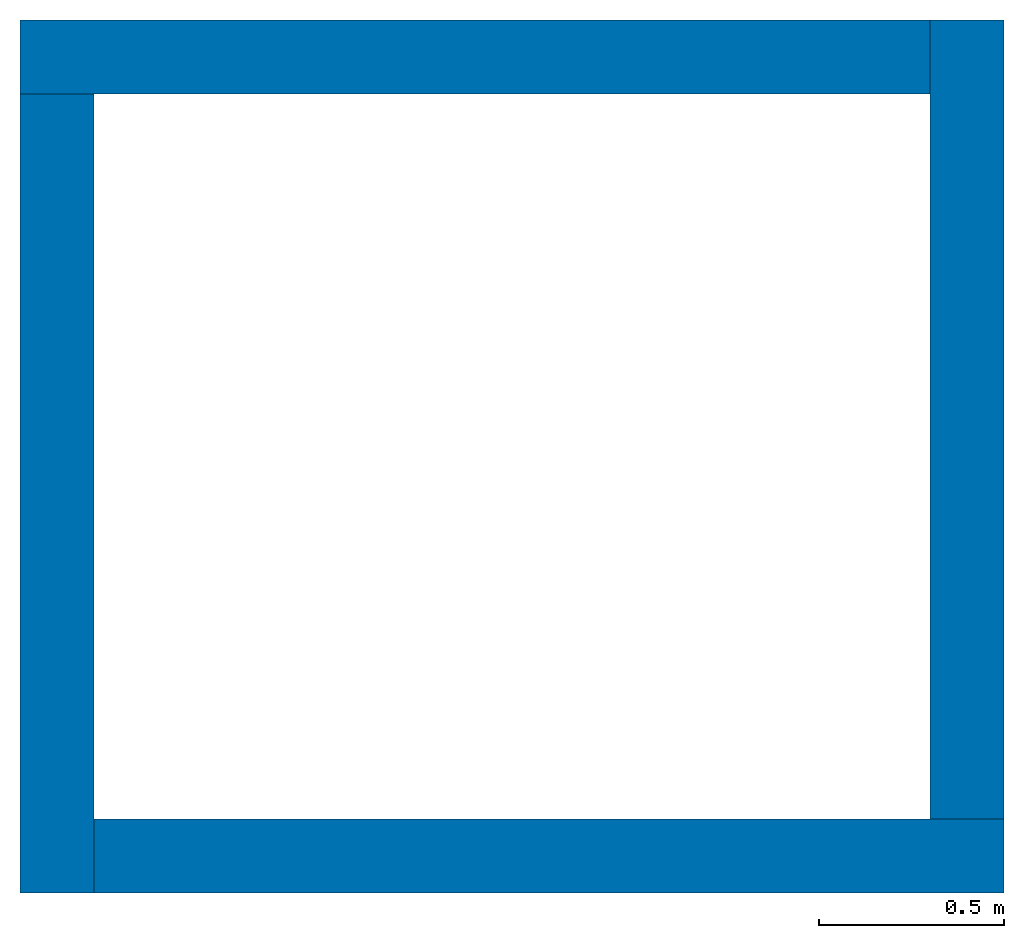
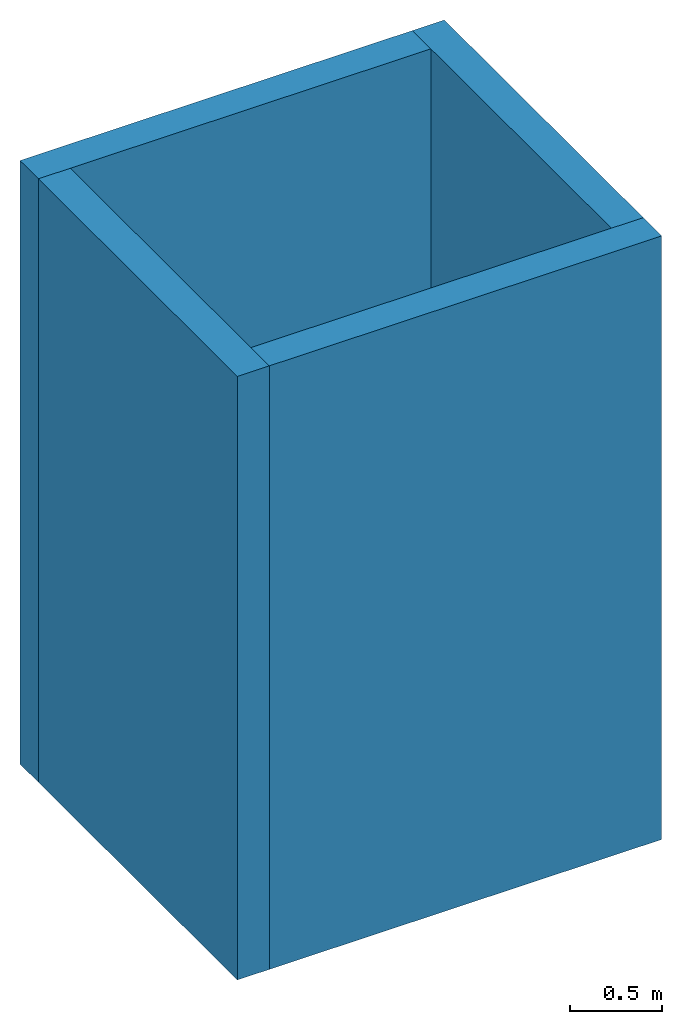
# One storey: 4 walls.
"""IFC2X3 building model written with IfcOpenShell, lengths in millimetres."""

from ifc_helpers import new_model, entity, si_unit, converted_unit, derived_unit, direction, frame, frame_2d, origin, place, context, subcontext, project, spatial, rectangle, extrude, material, layer, layer_set, layer_usage, type_object, element, save


model = new_model("IFC2X3")

# Units and contexts
model_context = context("Model", 3, precision=0.01, world=origin(), true_north=direction((6.12303176911189e-17, 1.0)))
context_of_model = context(None, 3, precision=0.01, world=origin(), true_north=direction((6.12303176911189e-17, 1.0)))
body_context = subcontext(model_context, "Body", "Model", "MODEL_VIEW")
ifc_project = project(units=[si_unit("LENGTHUNIT", "METRE", prefix="MILLI"), si_unit("AREAUNIT", "SQUARE_METRE"), si_unit("VOLUMEUNIT", "CUBIC_METRE"), converted_unit("PLANEANGLEUNIT", "DEGREE", entity("IfcRatioMeasure", 0.0174532925199433), si_unit("PLANEANGLEUNIT", "RADIAN"), dimensions=[0, 0, 0, 0, 0, 0, 0]), si_unit("MASSUNIT", "GRAM", prefix="KILO"), derived_unit("MASSDENSITYUNIT", [(si_unit("MASSUNIT", "GRAM", prefix="KILO"), 1), (si_unit("LENGTHUNIT", "METRE"), -3)]), si_unit("TIMEUNIT", "SECOND"), si_unit("FREQUENCYUNIT", "HERTZ"), si_unit("THERMODYNAMICTEMPERATUREUNIT", "DEGREE_CELSIUS"), derived_unit("THERMALTRANSMITTANCEUNIT", [(si_unit("MASSUNIT", "GRAM", prefix="KILO"), 1), (si_unit("THERMODYNAMICTEMPERATUREUNIT", "KELVIN"), -1), (si_unit("TIMEUNIT", "SECOND"), -3)]), derived_unit("VOLUMETRICFLOWRATEUNIT", [(si_unit("LENGTHUNIT", "METRE"), 3), (si_unit("TIMEUNIT", "SECOND"), -1)]), si_unit("ELECTRICCURRENTUNIT", "AMPERE"), si_unit("ELECTRICVOLTAGEUNIT", "VOLT"), si_unit("POWERUNIT", "WATT"), si_unit("FORCEUNIT", "NEWTON", prefix="KILO"), si_unit("ILLUMINANCEUNIT", "LUX"), si_unit("LUMINOUSFLUXUNIT", "LUMEN"), si_unit("LUMINOUSINTENSITYUNIT", "CANDELA"), derived_unit("USERDEFINED", [(si_unit("MASSUNIT", "GRAM", prefix="KILO"), -1), (si_unit("LENGTHUNIT", "METRE"), -2), (si_unit("TIMEUNIT", "SECOND"), 3), (si_unit("LUMINOUSFLUXUNIT", "LUMEN"), 1)]), derived_unit("LINEARVELOCITYUNIT", [(si_unit("LENGTHUNIT", "METRE"), 1), (si_unit("TIMEUNIT", "SECOND"), -1)]), si_unit("PRESSUREUNIT", "PASCAL"), derived_unit("USERDEFINED", [(si_unit("LENGTHUNIT", "METRE"), -2), (si_unit("MASSUNIT", "GRAM", prefix="KILO"), 1), (si_unit("TIMEUNIT", "SECOND"), -2)])], contexts=[model_context, context_of_model])

# Site, building, storey
site_placement = place(None, origin())
site = spatial("IfcSite", under=ifc_project, at=site_placement, CompositionType="ELEMENT")
building_placement = place(site_placement, origin())
building = spatial("IfcBuilding", under=site, at=building_placement, CompositionType="ELEMENT")
storey_placement = place(building_placement, origin())
storey = spatial("IfcBuildingStorey", under=building, at=storey_placement, Name="Level 1", CompositionType="ELEMENT", Elevation=0.0)

# Walls
ifc_material = material(Name="Default Wall")
ifc_layer = layer(ifc_material, 200.0)
ifc_layer_set = layer_set([ifc_layer], Name="Basic Wall:Wall 1")
ifc_layer_usage_1 = layer_usage(ifc_layer_set, "AXIS2", "NEGATIVE", 100.0)
wall_type = type_object("IfcWallType", Name="Basic Wall:Wall 1", PredefinedType="STANDARD", material=ifc_layer_set)
wall_1_placement = place(storey_placement, frame((524.569707401033, 3115.31841652324, 0.0)))
element("IfcWallStandardCase", 1, at=wall_1_placement, inside=storey, type_object=wall_type, material=ifc_layer_usage_1, Name="Basic Wall:Wall 1:2474", ObjectType="Basic Wall:Wall 1", context=body_context, shape_type="SweptSolid", body=[
    extrude(rectangle(XDim=2460.0, YDim=200.0, at=frame_2d((1230.0, 0.0), x_axis=(-1.0, 0.0))), origin(), (0.0, 0.0, 1.0), 4000.0),
])
ifc_layer_usage_2 = layer_usage(ifc_layer_set, "AXIS2", "NEGATIVE", 100.0)
wall_2_placement = place(storey_placement, frame((624.569707401033, 855.318416523237, 0.0), z_axis=(0.0, 0.0, 1.0), x_axis=(0.0, 1.0, 0.0)))
element("IfcWallStandardCase", 2, at=wall_2_placement, inside=storey, type_object=wall_type, material=ifc_layer_usage_2, Name="Basic Wall:Wall 1:2475", ObjectType="Basic Wall:Wall 1", context=body_context, shape_type="SweptSolid", body=[
    extrude(rectangle(XDim=2160.0, YDim=200.0, at=frame_2d((1080.0, 0.0), x_axis=(-1.0, 0.0))), origin(), (0.0, 0.0, 1.0), 4000.0),
])
ifc_layer_usage_3 = layer_usage(ifc_layer_set, "AXIS2", "NEGATIVE", 100.0)
wall_3_placement = place(storey_placement, frame((3184.56970740103, 955.318416523237, 0.0), z_axis=(0.0, 0.0, 1.0), x_axis=(-1.0, 0.0, 0.0)))
element("IfcWallStandardCase", 3, at=wall_3_placement, inside=storey, type_object=wall_type, material=ifc_layer_usage_3, Name="Basic Wall:Wall 1:2476", ObjectType="Basic Wall:Wall 1", context=body_context, shape_type="SweptSolid", body=[
    extrude(rectangle(XDim=2460.0, YDim=200.0, at=frame_2d((1230.0, 0.0), x_axis=(-1.0, 0.0))), origin(), (0.0, 0.0, 1.0), 4000.0),
])
ifc_layer_usage_4 = layer_usage(ifc_layer_set, "AXIS2", "NEGATIVE", 100.0)
wall_4_placement = place(storey_placement, frame((3084.56970740103, 3215.31841652324, 0.0), z_axis=(0.0, 0.0, 1.0), x_axis=(0.0, -1.0, 0.0)))
element("IfcWallStandardCase", 4, at=wall_4_placement, inside=storey, type_object=wall_type, material=ifc_layer_usage_4, Name="Basic Wall:Wall 1:2477", ObjectType="Basic Wall:Wall 1", context=body_context, shape_type="SweptSolid", body=[
    extrude(rectangle(XDim=2160.0, YDim=200.0, at=frame_2d((1080.0, 0.0), x_axis=(-1.0, 0.0))), origin(), (0.0, 0.0, 1.0), 4000.0),
])

save(model, "model.ifc")
